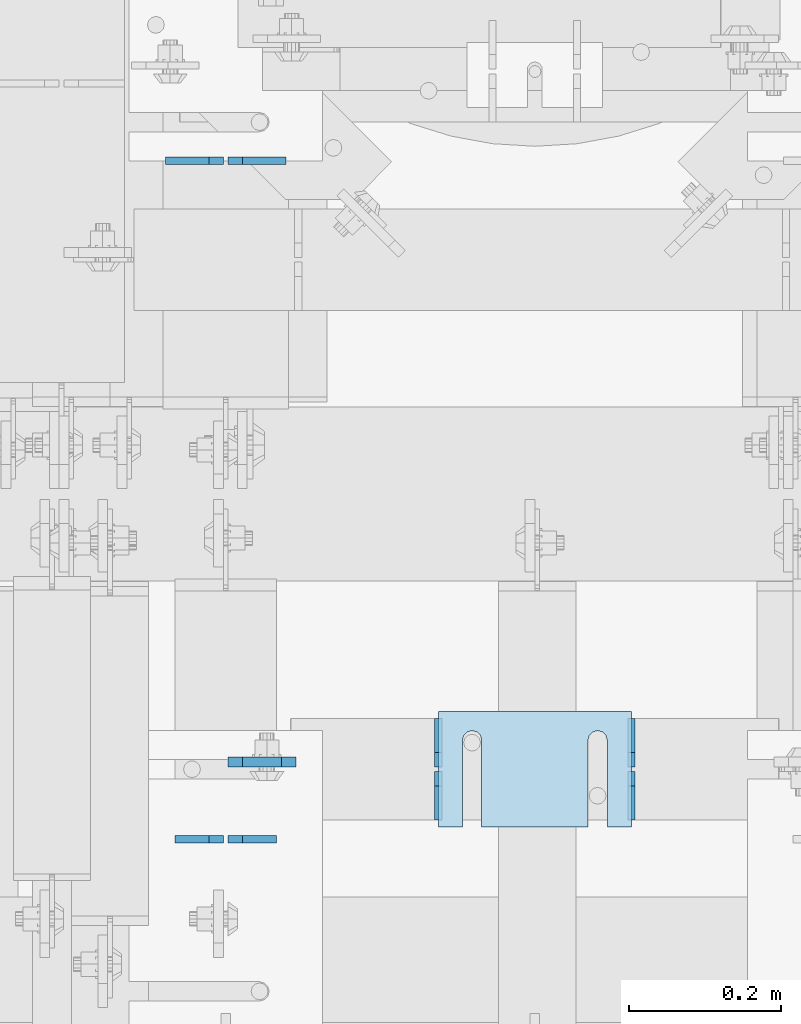
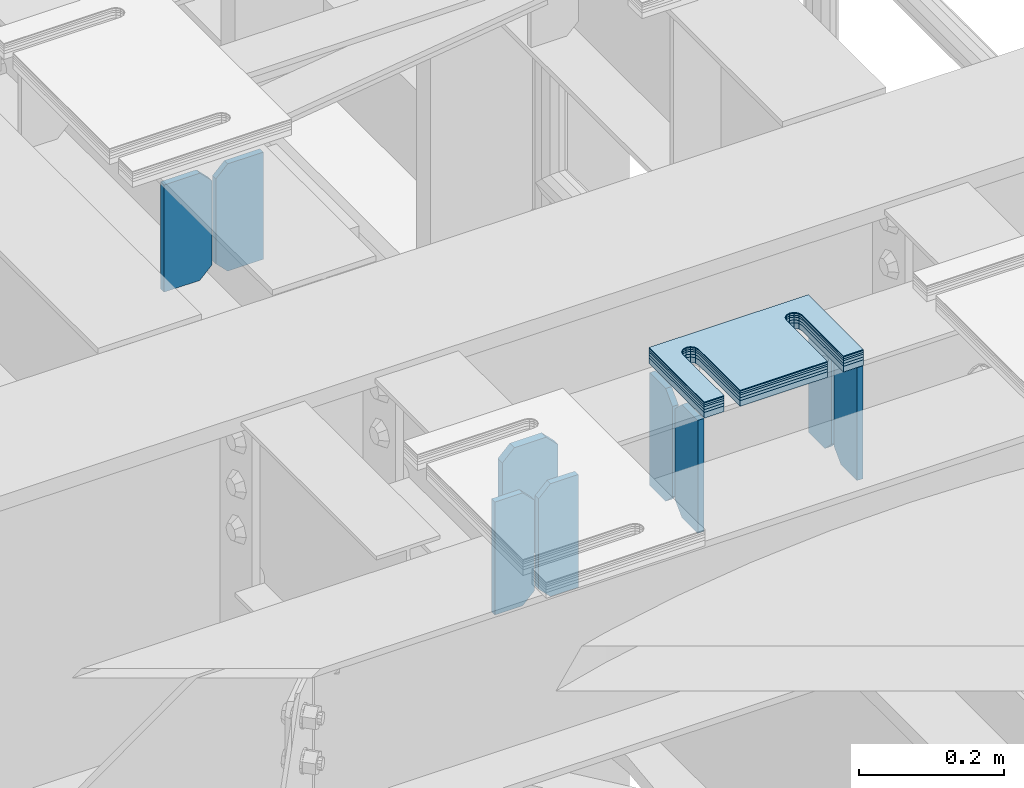
# One storey, part 1576 of 1876: 15 plates, 9 elements without a shape of their own.
"""IFC2X3 building model written with IfcOpenShell, lengths in millimetres."""

from ifc_helpers import new_model, si_unit, frame, origin_with_axes, place, context, subcontext, project, spatial, faceted_brep, material, type_object, element, aggregate, save


model = new_model("IFC2X3")

# Units and contexts
model_context = context("Model", 3, precision=1e-05, world=origin_with_axes())
body_context = subcontext(model_context, "Body", "Model", "MODEL_VIEW")
ifc_project = project(units=[si_unit("LENGTHUNIT", "METRE", prefix="MILLI"), si_unit("AREAUNIT", "SQUARE_METRE"), si_unit("VOLUMEUNIT", "CUBIC_METRE"), si_unit("MASSUNIT", "GRAM", prefix="KILO"), si_unit("TIMEUNIT", "SECOND"), si_unit("PLANEANGLEUNIT", "RADIAN"), si_unit("SOLIDANGLEUNIT", "STERADIAN"), si_unit("THERMODYNAMICTEMPERATUREUNIT", "DEGREE_CELSIUS"), si_unit("LUMINOUSINTENSITYUNIT", "LUMEN")], contexts=[model_context])

# Site, building, storey
site_placement = place(None, origin_with_axes())
site = spatial("IfcSite", under=ifc_project, at=site_placement, CompositionType="ELEMENT")
building_placement = place(site_placement, origin_with_axes())
building = spatial("IfcBuilding", under=site, at=building_placement, Name="Undefined", CompositionType="ELEMENT")
storey_placement = place(building_placement, origin_with_axes())
storey = spatial("IfcBuildingStorey", under=building, at=storey_placement, Name="Undefined", CompositionType="ELEMENT", Elevation=0.0)

# Assembly, plates
assembly_1_placement = place(storey_placement, origin_with_axes())
assembly_1 = element("IfcElementAssembly", 1, at=assembly_1_placement, inside=storey, Name="BEAM", AssemblyPlace="NOTDEFINED", PredefinedType="RIGID_FRAME")
ifc_material = material(Name="STEEL/A36")
plate_type_1 = type_object("IfcPlateType", PredefinedType="NOTDEFINED")
plate_1_placement = place(assembly_1_placement, frame((4092.57517785198, 1962.15312686004, 17792.7000000684), z_axis=(0.0, 0.0, 1.0), x_axis=(-1.0, 0.0, 0.0)))
plate_1 = element("IfcPlate", 2, at=plate_1_placement, type_object=plate_type_1, material=ifc_material, Name="PLATE", context=body_context, shape_type="Brep", body=[
    faceted_brep([(0.0, -4.76249999999982, 0.0), (0.0, -4.76249999999982, 180.975006103516), (0.0, 4.76249999999982, 180.975006103516), (0.0, 4.76249999999982, 0.0), (57.1499977111816, -4.76249999999982, 180.975006103516), (57.1499977111816, 4.76249999999982, 180.975006103516), (76.1999969482422, -4.76249999999982, 161.925006866455), (76.1999969482422, 4.76249999999982, 161.925006866455), (76.1999969482422, -4.76249999999982, 19.0499992370605), (76.1999969482422, 4.76249999999982, 19.0499992370605), (57.1499977111816, -4.76249999999982, 0.0), (57.1499977111816, 4.76249999999982, 0.0)], [[[0, 1, 2, 3]], [[1, 4, 5, 2]], [[4, 6, 7, 5]], [[6, 8, 9, 7]], [[8, 10, 11, 9]], [[10, 0, 3, 11]], [[5, 7, 9, 11, 3, 2]], [[10, 8, 6, 4, 1, 0]]]),
])
plate_2_placement = place(assembly_1_placement, frame((4010.02517785198, 1962.15312686004, 17792.7), z_axis=(0.0, 0.0, 1.0), x_axis=(-1.0, 0.0, 0.0)))
plate_2 = element("IfcPlate", 3, at=plate_2_placement, type_object=plate_type_1, material=ifc_material, Name="PLATE", context=body_context, shape_type="Brep", body=[
    faceted_brep([(0.0, -4.76249999999982, 19.0499992370605), (0.0, -4.76249999999982, 161.925006866455), (0.0, 4.76249999999982, 161.925006866455), (0.0, 4.76249999999982, 19.0499992370605), (19.0499992370605, -4.76249999999982, 180.975006103516), (19.0499992370605, 4.76249999999982, 180.975006103516), (76.1999969482422, -4.76249999999982, 180.975006103516), (76.1999969482422, 4.76249999999982, 180.975006103516), (76.1999969482422, -4.76250000000073, 0.0), (76.1999969482422, 4.76250000000073, 0.0), (19.0499992370605, -4.76249999999982, 0.0), (19.0499992370605, 4.76249999999982, 0.0)], [[[0, 1, 2, 3]], [[1, 4, 5, 2]], [[4, 6, 7, 5]], [[6, 8, 9, 7]], [[8, 10, 11, 9]], [[10, 0, 3, 11]], [[5, 7, 9, 11, 3, 2]], [[10, 8, 6, 4, 1, 0]]]),
])
aggregate(assembly_1, [plate_1, plate_2])

assembly_2_placement = place(storey_placement, origin_with_axes())
assembly_2 = element("IfcElementAssembly", 4, at=assembly_2_placement, inside=storey, Name="BEAM", AssemblyPlace="NOTDEFINED", PredefinedType="RIGID_FRAME")
plate_type_2 = type_object("IfcPlateType", PredefinedType="NOTDEFINED")
plate_3_placement = place(assembly_2_placement, frame((4546.61120385295, 1095.37530517578, 17784.7625), z_axis=(0.0, 0.0, 1.0), x_axis=(0.0, 1.0, 0.0)))
plate_3 = element("IfcPlate", 5, at=plate_3_placement, type_object=plate_type_2, material=ifc_material, Name="PLATE", context=body_context, shape_type="Brep", body=[
    faceted_brep([(0.0, -4.76249999999982, 0.0), (0.0, -4.76249999999982, 190.5), (0.0, 4.76249999999982, 190.5), (0.0, 4.76249999999982, 0.0), (44.4500007629395, -4.76249999999982, 190.5), (44.4500007629395, 4.76249999999982, 190.5), (63.5, -4.76249999999982, 171.450000762939), (63.5, 4.76249999999982, 171.450000762939), (63.5, -4.76249999999982, 19.0499992370605), (63.5, 4.76249999999982, 19.0499992370605), (44.4500007629395, -4.76249999999982, 0.0), (44.4500007629395, 4.76249999999982, 0.0)], [[[0, 1, 2, 3]], [[1, 4, 5, 2]], [[4, 6, 7, 5]], [[6, 8, 9, 7]], [[8, 10, 11, 9]], [[10, 0, 3, 11]], [[5, 7, 9, 11, 3, 2]], [[10, 8, 6, 4, 1, 0]]]),
])
plate_4_placement = place(assembly_2_placement, frame((4546.61120385295, 1165.22530517578, 17784.7625), z_axis=(0.0, 0.0, 1.0), x_axis=(0.0, 1.0, 0.0)))
plate_4 = element("IfcPlate", 6, at=plate_4_placement, type_object=plate_type_2, material=ifc_material, Name="PLATE", context=body_context, shape_type="Brep", body=[
    faceted_brep([(0.0, -4.76249999999982, 19.0499992370605), (0.0, -4.76249999999982, 171.450000762939), (0.0, 4.76249999999982, 171.450000762939), (0.0, 4.76249999999982, 19.0499992370605), (19.0499992370605, -4.76249999999982, 190.5), (19.0499992370605, 4.76249999999982, 190.5), (63.5, -4.76249999999982, 190.5), (63.5, 4.76249999999982, 190.5), (63.5, -4.76249999999982, 0.0), (63.5, 4.76249999999982, 0.0), (19.0499992370605, -4.76249999999982, 0.0), (19.0499992370605, 4.76249999999982, 0.0)], [[[0, 1, 2, 3]], [[1, 4, 5, 2]], [[4, 6, 7, 5]], [[6, 8, 9, 7]], [[8, 10, 11, 9]], [[10, 0, 3, 11]], [[5, 7, 9, 11, 3, 2]], [[10, 8, 6, 4, 1, 0]]]),
])
plate_5_placement = place(assembly_2_placement, frame((4292.61203778016, 1095.37530517578, 17784.7625), z_axis=(0.0, 0.0, 1.0), x_axis=(0.0, 1.0, 0.0)))
plate_5 = element("IfcPlate", 7, at=plate_5_placement, type_object=plate_type_2, material=ifc_material, Name="PLATE", context=body_context, shape_type="Brep", body=[
    faceted_brep([(0.0, -4.76249999999982, 0.0), (0.0, -4.76249999999982, 190.5), (0.0, 4.76249999999982, 190.5), (0.0, 4.76249999999982, 0.0), (44.4500007629395, -4.76249999999982, 190.5), (44.4500007629395, 4.76249999999982, 190.5), (63.5, -4.76249999999982, 171.450000762939), (63.5, 4.76249999999982, 171.450000762939), (63.5, -4.76249999999982, 19.0499992370605), (63.5, 4.76249999999982, 19.0499992370605), (44.4500007629395, -4.76249999999982, 0.0), (44.4500007629395, 4.76249999999982, 0.0)], [[[0, 1, 2, 3]], [[1, 4, 5, 2]], [[4, 6, 7, 5]], [[6, 8, 9, 7]], [[8, 10, 11, 9]], [[10, 0, 3, 11]], [[5, 7, 9, 11, 3, 2]], [[10, 8, 6, 4, 1, 0]]]),
])
plate_6_placement = place(assembly_2_placement, frame((4292.61203778016, 1165.22530517578, 17784.7625), z_axis=(0.0, 0.0, 1.0), x_axis=(0.0, 1.0, 0.0)))
plate_6 = element("IfcPlate", 8, at=plate_6_placement, type_object=plate_type_2, material=ifc_material, Name="PLATE", context=body_context, shape_type="Brep", body=[
    faceted_brep([(0.0, -4.76249999999982, 19.0499992370605), (0.0, -4.76249999999982, 171.450000762939), (0.0, 4.76249999999982, 171.450000762939), (0.0, 4.76249999999982, 19.0499992370605), (19.0499992370605, -4.76249999999982, 190.5), (19.0499992370605, 4.76249999999982, 190.5), (63.5, -4.76249999999982, 190.5), (63.5, 4.76249999999982, 190.5), (63.5, -4.76249999999982, 0.0), (63.5, 4.76249999999982, 0.0), (19.0499992370605, -4.76249999999982, 0.0), (19.0499992370605, 4.76249999999982, 0.0)], [[[0, 1, 2, 3]], [[1, 4, 5, 2]], [[4, 6, 7, 5]], [[6, 8, 9, 7]], [[8, 10, 11, 9]], [[10, 0, 3, 11]], [[5, 7, 9, 11, 3, 2]], [[10, 8, 6, 4, 1, 0]]]),
])
aggregate(assembly_2, [plate_3, plate_4, plate_5, plate_6])

assembly_3_placement = place(storey_placement, origin_with_axes())
assembly_3 = element("IfcElementAssembly", 9, at=assembly_3_placement, inside=storey, Name="BEAM", AssemblyPlace="NOTDEFINED", PredefinedType="RIGID_FRAME")
plate_7_placement = place(assembly_3_placement, frame((4079.87517785198, 1069.97506254369, 17784.7625), z_axis=(0.0, 0.0, 1.0), x_axis=(-1.0, 0.0, 0.0)))
plate_7 = element("IfcPlate", 10, at=plate_7_placement, type_object=plate_type_2, material=ifc_material, Name="PLATE", context=body_context, shape_type="Brep", body=[
    faceted_brep([(0.0, -4.76249999999982, 0.0), (0.0, -4.76249999999982, 190.5), (0.0, 4.76249999999982, 190.5), (0.0, 4.76249999999982, 0.0), (44.4500007629395, -4.76249999999982, 190.5), (44.4500007629395, 4.76249999999982, 190.5), (63.5, -4.76249999999982, 171.450000762939), (63.5, 4.76249999999982, 171.450000762939), (63.5, -4.76249999999982, 19.0499992370605), (63.5, 4.76249999999982, 19.0499992370605), (44.4500007629395, -4.76249999999982, 0.0), (44.4500007629395, 4.76249999999982, 0.0)], [[[0, 1, 2, 3]], [[1, 4, 5, 2]], [[4, 6, 7, 5]], [[6, 8, 9, 7]], [[8, 10, 11, 9]], [[10, 0, 3, 11]], [[5, 7, 9, 11, 3, 2]], [[10, 8, 6, 4, 1, 0]]]),
])
plate_8_placement = place(assembly_3_placement, frame((4010.02517785198, 1069.97506254369, 17784.7625), z_axis=(0.0, 0.0, 1.0), x_axis=(-1.0, 0.0, 0.0)))
plate_8 = element("IfcPlate", 11, at=plate_8_placement, type_object=plate_type_2, material=ifc_material, Name="PLATE", context=body_context, shape_type="Brep", body=[
    faceted_brep([(0.0, -4.76249999999982, 19.0499992370605), (0.0, -4.76249999999982, 171.450000762939), (0.0, 4.76249999999982, 171.450000762939), (0.0, 4.76249999999982, 19.0499992370605), (19.0499992370605, -4.76249999999982, 190.5), (19.0499992370605, 4.76249999999982, 190.5), (63.5, -4.76249999999982, 190.5), (63.5, 4.76249999999982, 190.5), (63.5, -4.76249999999982, 0.0), (63.5, 4.76249999999982, 0.0), (19.0499992370605, -4.76249999999982, 0.0), (19.0499992370605, 4.76249999999982, 0.0)], [[[0, 1, 2, 3]], [[1, 4, 5, 2]], [[4, 6, 7, 5]], [[6, 8, 9, 7]], [[8, 10, 11, 9]], [[10, 0, 3, 11]], [[5, 7, 9, 11, 3, 2]], [[10, 8, 6, 4, 1, 0]]]),
])
plate_type_3 = type_object("IfcPlateType", PredefinedType="NOTDEFINED")
plate_9_placement = place(assembly_3_placement, frame((4016.37517785198, 1171.57530527115, 17786.35), z_axis=(0.0, 0.0, 1.0), x_axis=(1.0, 0.0, 0.0)))
plate_9 = element("IfcPlate", 12, at=plate_9_placement, type_object=plate_type_3, material=ifc_material, Name="PLATE", context=body_context, shape_type="Brep", body=[
    faceted_brep([(0.0, -6.35000000000196, 19.0499992370605), (0.0, -6.34999999999991, 169.862506866455), (0.0, 6.34999999999991, 169.862506866455), (0.0, 6.35000000000105, 19.0499992370605), (19.0499992370605, -6.34999999999991, 188.912506103516), (19.0499992370605, 6.34999999999991, 188.912506103516), (69.8500022888184, -6.34999999999991, 188.912506103516), (69.8500022888184, 6.34999999999991, 188.912506103516), (88.9000015258789, -6.34999999999991, 169.862506866455), (88.9000015258789, 6.34999999999991, 169.862506866455), (88.9000015258789, -6.34999999999991, 0.0), (88.9000015258789, 6.34999999999991, 0.0), (19.0499992370642, -6.35000000000105, 0.0), (19.0499992370633, 6.35000000000105, 0.0)], [[[0, 1, 2, 3]], [[1, 4, 5, 2]], [[4, 6, 7, 5]], [[6, 8, 9, 7]], [[8, 10, 11, 9]], [[10, 12, 13, 11]], [[12, 0, 3, 13]], [[5, 7, 9, 11, 13, 3, 2]], [[12, 10, 8, 6, 4, 1, 0]]]),
])
aggregate(assembly_3, [plate_7, plate_8, plate_9])

# Assembly, plate
assembly_4_placement = place(storey_placement, origin_with_axes())
assembly_4 = element("IfcElementAssembly", 13, at=assembly_4_placement, inside=storey, Name="SHIM PLATE", AssemblyPlace="NOTDEFINED", PredefinedType="RIGID_FRAME")
plate_type_4 = type_object("IfcPlateType", PredefinedType="NOTDEFINED")
plate_10_placement = place(assembly_4_placement, frame((4546.61256679875, 1238.25105434561, 18009.3925), z_axis=(0.0, -1.0, 0.0), x_axis=(-1.0, 0.0, 0.0)))
plate_10 = element("IfcPlate", 14, at=plate_10_placement, type_object=plate_type_4, material=ifc_material, Name="SHIM PLATE", context=body_context, shape_type="Brep", body=[
    faceted_brep([(31.7473236467022, -0.793499999999767, 152.398895263674), (31.7495452849444, -0.793499999999767, 38.0994505459066), (31.7495452849444, 0.793499999999767, 38.0994505459066), (31.7473236467022, 0.793499999999767, 152.398895263674), (33.4510181364694, -0.793499999999767, 31.7494480392982), (33.4510181364694, 0.793499999999767, 31.7494480392982), (38.0995388011806, -0.793499999999767, 27.1009216783834), (38.0995388011806, 0.793499999999767, 27.1009216783834), (44.4495392228328, -0.793499999999767, 25.3994410457015), (44.4495392228328, 0.793499999999767, 25.3994410457015), (50.7995409628356, -0.793499999999767, 27.1009167582527), (50.7995409628356, 0.793499999999767, 27.1009167582527), (55.4480652293469, -0.793499999999767, 31.7494395173824), (55.4480652293469, 0.793499999999767, 31.7494395173824), (57.14954300102, -0.793499999999767, 38.0994407056476), (57.14954300102, 0.793499999999767, 38.0994407056476), (57.1473213626687, -0.793499999999767, 152.398894419415), (57.1473213626687, 0.793499999999767, 152.398895263676), (9.09494701772928e-13, -0.793499999999767, 0.0), (1.98268335225293e-05, -0.793499999999767, 152.398895263672), (1.98268335225293e-05, 0.793499999999767, 152.398895263672), (9.09494701772928e-13, 0.793499999999767, 0.0), (253.999542236328, -0.793499999999767, 6.16182660451159e-11), (253.999542236328, 0.793499999999767, 6.16182660451159e-11), (253.999557495107, -0.793499999999767, 152.398895263688), (253.999557495107, 0.793499999999767, 152.398895263688), (222.247321362667, 0.793499999999767, 152.398895263686), (222.247321362667, -0.793499999999767, 152.398895410166), (222.249543001019, 0.793499999999767, 38.0994416963979), (222.249543001019, -0.793499999999767, 38.0994416963979), (220.548065229345, 0.793499999999767, 31.7494405081325), (220.548065229345, -0.793499999999767, 31.7494405081325), (215.899540962834, 0.793499999999767, 27.100917749003), (215.899540962834, -0.793499999999767, 27.100917749003), (209.549539222831, 0.793499999999767, 25.3994420364518), (209.549539222831, -0.793499999999767, 25.3994420364518), (203.199538801179, 0.793499999999767, 27.1009226691335), (203.199538801179, -0.793499999999767, 27.1009226691335), (198.551018136468, 0.793499999999767, 31.7494490300483), (198.551018136468, -0.793499999999767, 31.7494490300483), (196.849545284943, 0.793499999999767, 38.0994515366567), (196.849545284943, -0.793499999999767, 38.0994515366567), (196.847323646701, -0.793499999999767, 152.398895263684), (196.847323646701, 0.793499999999767, 152.398895263684)], [[[0, 1, 2, 3]], [[4, 5, 2, 1]], [[6, 7, 5, 4]], [[8, 9, 7, 6]], [[10, 11, 9, 8]], [[12, 13, 11, 10]], [[14, 15, 13, 12]], [[16, 17, 15, 14]], [[18, 19, 20, 21]], [[22, 18, 21, 23]], [[24, 22, 23, 25]], [[24, 25, 26, 27]], [[27, 26, 28, 29]], [[29, 28, 30, 31]], [[31, 30, 32, 33]], [[33, 32, 34, 35]], [[35, 34, 36, 37]], [[37, 36, 38, 39]], [[39, 38, 40, 41]], [[42, 41, 40, 43]], [[12, 10, 8, 6, 4, 1, 0, 19, 18, 22, 24, 27, 29, 31, 33, 35, 37, 39, 41, 42, 16, 14]], [[20, 19, 0, 3]], [[43, 40, 38, 36, 34, 32, 30, 28, 26, 25, 23, 21, 20, 3, 2, 5, 7, 9, 11, 13, 15, 17]], [[42, 43, 17, 16]]]),
])
aggregate(assembly_4, [plate_10])

assembly_5_placement = place(storey_placement, origin_with_axes())
assembly_5 = element("IfcElementAssembly", 15, at=assembly_5_placement, inside=storey, Name="SHIM PLATE", AssemblyPlace="NOTDEFINED", PredefinedType="RIGID_FRAME")
plate_type_5 = type_object("IfcPlateType", PredefinedType="NOTDEFINED")
plate_11_placement = place(assembly_5_placement, frame((4546.61256679889, 1238.25105434514, 18007.0115), z_axis=(0.0, -1.0, 0.0), x_axis=(-1.0, 0.0, 0.0)))
plate_11 = element("IfcPlate", 16, at=plate_11_placement, type_object=plate_type_5, material=ifc_material, Name="SHIM PLATE", context=body_context, shape_type="Brep", body=[
    faceted_brep([(31.7473236467022, -1.58750000000146, 152.398895263674), (31.7495452849444, -1.58750000000146, 38.0994505459066), (31.7495452849444, 1.58750000000146, 38.0994505459066), (31.7473236467022, 1.58750000000146, 152.398895263674), (33.4510181364694, -1.58750000000146, 31.7494480392982), (33.4510181364694, 1.58750000000146, 31.7494480392982), (38.0995388011806, -1.58750000000146, 27.1009216783834), (38.0995388011806, 1.58750000000146, 27.1009216783834), (44.4495392228328, -1.58750000000146, 25.3994410457015), (44.4495392228328, 1.58750000000146, 25.3994410457015), (50.7995409628356, -1.58750000000146, 27.1009167582527), (50.7995409628356, 1.58750000000146, 27.1009167582527), (55.4480652293469, -1.58750000000146, 31.7494395173824), (55.4480652293469, 1.58750000000146, 31.7494395173824), (57.14954300102, -1.58750000000146, 38.0994407056476), (57.14954300102, 1.58750000000146, 38.0994407056476), (57.1473213626687, -1.58750000000146, 152.398894419415), (57.1473213626687, 1.58750000000146, 152.398895263676), (9.09494701772928e-13, -1.58750000000146, 4.54747350886464e-13), (1.98264133359771e-05, -1.58750000000146, 152.398895263672), (1.98264133359771e-05, 1.58750000000146, 152.398895263672), (9.09494701772928e-13, 1.58750000000146, 4.54747350886464e-13), (253.999542236328, -1.58750000000146, 6.16182660451159e-11), (253.999542236328, 1.58750000000146, 6.16182660451159e-11), (253.999557495107, -1.58750000000146, 152.398895263688), (253.999557495107, 1.58750000000146, 152.398895263688), (222.247321362667, 1.58750000000146, 152.398895263686), (222.247321362667, -1.58750000000146, 152.398895410166), (222.249543001019, 1.58750000000146, 38.0994416963979), (222.249543001019, -1.58750000000146, 38.0994416963979), (220.548065229345, 1.58750000000146, 31.7494405081325), (220.548065229345, -1.58750000000146, 31.7494405081325), (215.899540962834, 1.58750000000146, 27.100917749003), (215.899540962834, -1.58750000000146, 27.100917749003), (209.549539222831, 1.58750000000146, 25.3994420364518), (209.549539222831, -1.58750000000146, 25.3994420364518), (203.199538801179, 1.58750000000146, 27.1009226691335), (203.199538801179, -1.58750000000146, 27.1009226691335), (198.551018136468, 1.58750000000146, 31.7494490300483), (198.551018136468, -1.58750000000146, 31.7494490300483), (196.849545284943, 1.58750000000146, 38.0994515366567), (196.849545284943, -1.58750000000146, 38.0994515366567), (196.847323646701, -1.58750000000146, 152.398895263684), (196.847323646701, 1.58750000000146, 152.398895263684)], [[[0, 1, 2, 3]], [[4, 5, 2, 1]], [[6, 7, 5, 4]], [[8, 9, 7, 6]], [[10, 11, 9, 8]], [[12, 13, 11, 10]], [[14, 15, 13, 12]], [[16, 17, 15, 14]], [[18, 19, 20, 21]], [[22, 18, 21, 23]], [[24, 22, 23, 25]], [[24, 25, 26, 27]], [[27, 26, 28, 29]], [[29, 28, 30, 31]], [[31, 30, 32, 33]], [[33, 32, 34, 35]], [[35, 34, 36, 37]], [[37, 36, 38, 39]], [[39, 38, 40, 41]], [[42, 41, 40, 43]], [[12, 10, 8, 6, 4, 1, 0, 19, 18, 22, 24, 27, 29, 31, 33, 35, 37, 39, 41, 42, 16, 14]], [[20, 19, 0, 3]], [[43, 40, 38, 36, 34, 32, 30, 28, 26, 25, 23, 21, 20, 3, 2, 5, 7, 9, 11, 13, 15, 17]], [[42, 43, 17, 16]]]),
])
aggregate(assembly_5, [plate_11])

assembly_6_placement = place(storey_placement, origin_with_axes())
assembly_6 = element("IfcElementAssembly", 17, at=assembly_6_placement, inside=storey, Name="SHIM PLATE", AssemblyPlace="NOTDEFINED", PredefinedType="RIGID_FRAME")
plate_12_placement = place(assembly_6_placement, frame((4546.61256679903, 1238.25105434468, 18003.8365), z_axis=(0.0, -1.0, 0.0), x_axis=(-1.0, 0.0, 0.0)))
plate_12 = element("IfcPlate", 18, at=plate_12_placement, type_object=plate_type_5, material=ifc_material, Name="SHIM PLATE", context=body_context, shape_type="Brep", body=[
    faceted_brep([(31.7473236467022, -1.58750000000146, 152.398895263674), (31.7495452849444, -1.58750000000146, 38.0994505459066), (31.7495452849444, 1.58750000000146, 38.0994505459066), (31.7473236467022, 1.58750000000146, 152.398895263674), (33.4510181364694, -1.58750000000146, 31.7494480392982), (33.4510181364694, 1.58750000000146, 31.7494480392982), (38.0995388011806, -1.58750000000146, 27.1009216783834), (38.0995388011806, 1.58750000000146, 27.1009216783834), (44.4495392228328, -1.58750000000146, 25.3994410457015), (44.4495392228328, 1.58750000000146, 25.3994410457015), (50.7995409628356, -1.58750000000146, 27.1009167582527), (50.7995409628356, 1.58750000000146, 27.1009167582527), (55.4480652293469, -1.58750000000146, 31.7494395173824), (55.4480652293469, 1.58750000000146, 31.7494395173824), (57.14954300102, -1.58750000000146, 38.0994407056476), (57.14954300102, 1.58750000000146, 38.0994407056476), (57.1473213626687, -1.58750000000146, 152.398894419415), (57.1473213626687, 1.58750000000146, 152.398895263676), (9.09494701772928e-13, -1.58750000000146, 4.54747350886464e-13), (1.98264133359771e-05, -1.58750000000146, 152.398895263672), (1.98264133359771e-05, 1.58750000000146, 152.398895263672), (9.09494701772928e-13, 1.58750000000146, 4.54747350886464e-13), (253.999542236328, -1.58750000000146, 6.16182660451159e-11), (253.999542236328, 1.58750000000146, 6.16182660451159e-11), (253.999557495107, -1.58750000000146, 152.398895263688), (253.999557495107, 1.58750000000146, 152.398895263688), (222.247321362667, 1.58750000000146, 152.398895263686), (222.247321362667, -1.58750000000146, 152.398895410166), (222.249543001019, 1.58750000000146, 38.0994416963979), (222.249543001019, -1.58750000000146, 38.0994416963979), (220.548065229345, 1.58750000000146, 31.7494405081325), (220.548065229345, -1.58750000000146, 31.7494405081325), (215.899540962834, 1.58750000000146, 27.100917749003), (215.899540962834, -1.58750000000146, 27.100917749003), (209.549539222831, 1.58750000000146, 25.3994420364518), (209.549539222831, -1.58750000000146, 25.3994420364518), (203.199538801179, 1.58750000000146, 27.1009226691335), (203.199538801179, -1.58750000000146, 27.1009226691335), (198.551018136468, 1.58750000000146, 31.7494490300483), (198.551018136468, -1.58750000000146, 31.7494490300483), (196.849545284943, 1.58750000000146, 38.0994515366567), (196.849545284943, -1.58750000000146, 38.0994515366567), (196.847323646701, -1.58750000000146, 152.398895263684), (196.847323646701, 1.58750000000146, 152.398895263684)], [[[0, 1, 2, 3]], [[4, 5, 2, 1]], [[6, 7, 5, 4]], [[8, 9, 7, 6]], [[10, 11, 9, 8]], [[12, 13, 11, 10]], [[14, 15, 13, 12]], [[16, 17, 15, 14]], [[18, 19, 20, 21]], [[22, 18, 21, 23]], [[24, 22, 23, 25]], [[24, 25, 26, 27]], [[27, 26, 28, 29]], [[29, 28, 30, 31]], [[31, 30, 32, 33]], [[33, 32, 34, 35]], [[35, 34, 36, 37]], [[37, 36, 38, 39]], [[39, 38, 40, 41]], [[42, 41, 40, 43]], [[12, 10, 8, 6, 4, 1, 0, 19, 18, 22, 24, 27, 29, 31, 33, 35, 37, 39, 41, 42, 16, 14]], [[20, 19, 0, 3]], [[43, 40, 38, 36, 34, 32, 30, 28, 26, 25, 23, 21, 20, 3, 2, 5, 7, 9, 11, 13, 15, 17]], [[42, 43, 17, 16]]]),
])
aggregate(assembly_6, [plate_12])

assembly_7_placement = place(storey_placement, origin_with_axes())
assembly_7 = element("IfcElementAssembly", 19, at=assembly_7_placement, inside=storey, Name="SHIM PLATE", AssemblyPlace="NOTDEFINED", PredefinedType="RIGID_FRAME")
plate_type_6 = type_object("IfcPlateType", PredefinedType="NOTDEFINED")
plate_13_placement = place(assembly_7_placement, frame((4546.61256679916, 1238.25105434422, 17999.868), z_axis=(0.0, -1.0, 0.0), x_axis=(-1.0, 0.0, 0.0)))
plate_13 = element("IfcPlate", 20, at=plate_13_placement, type_object=plate_type_6, material=ifc_material, Name="SHIM PLATE", context=body_context, shape_type="Brep", body=[
    faceted_brep([(31.7473236467022, -2.38100000000122, 152.398895263674), (31.7495452849444, -2.38100000000122, 38.0994505459066), (31.7495452849444, 2.38100000000122, 38.0994505459066), (31.7473236467022, 2.38100000000122, 152.398895263674), (33.4510181364694, -2.38100000000122, 31.7494480392982), (33.4510181364694, 2.38100000000122, 31.7494480392982), (38.0995388011806, -2.38100000000122, 27.1009216783834), (38.0995388011806, 2.38100000000122, 27.1009216783834), (44.4495392228328, -2.38100000000122, 25.3994410457015), (44.4495392228328, 2.38100000000122, 25.3994410457015), (50.7995409628356, -2.38100000000122, 27.1009167582527), (50.7995409628356, 2.38100000000122, 27.1009167582527), (55.4480652293469, -2.38100000000122, 31.7494395173824), (55.4480652293469, 2.38100000000122, 31.7494395173824), (57.14954300102, -2.38100000000122, 38.0994407056476), (57.14954300102, 2.38100000000122, 38.0994407056476), (57.1473213626687, -2.38100000000122, 152.398894419415), (57.1473213626687, 2.38100000000122, 152.398895263676), (0.0, -2.38100000000122, 4.54747350886464e-13), (1.98259931494249e-05, -2.38100000000122, 152.398895263672), (1.98259931494249e-05, 2.38100000000122, 152.398895263672), (0.0, 2.38100000000122, 4.54747350886464e-13), (253.999542236328, -2.38100000000122, 6.16182660451159e-11), (253.999542236328, 2.38100000000122, 6.16182660451159e-11), (253.999557495107, -2.38100000000122, 152.398895263688), (253.999557495107, 2.38100000000122, 152.398895263688), (222.247321362667, 2.38100000000122, 152.398895263686), (222.247321362667, -2.38100000000122, 152.398895410166), (222.249543001019, 2.38100000000122, 38.0994416963979), (222.249543001019, -2.38100000000122, 38.0994416963979), (220.548065229345, 2.38100000000122, 31.7494405081325), (220.548065229345, -2.38100000000122, 31.7494405081325), (215.899540962834, 2.38100000000122, 27.100917749003), (215.899540962834, -2.38100000000122, 27.100917749003), (209.549539222831, 2.38100000000122, 25.3994420364518), (209.549539222831, -2.38100000000122, 25.3994420364518), (203.199538801179, 2.38100000000122, 27.1009226691335), (203.199538801179, -2.38100000000122, 27.1009226691335), (198.551018136468, 2.38100000000122, 31.7494490300483), (198.551018136468, -2.38100000000122, 31.7494490300483), (196.849545284943, 2.38100000000122, 38.0994515366567), (196.849545284943, -2.38100000000122, 38.0994515366567), (196.847323646701, -2.38100000000122, 152.398895263684), (196.847323646701, 2.38100000000122, 152.398895263684)], [[[0, 1, 2, 3]], [[4, 5, 2, 1]], [[6, 7, 5, 4]], [[8, 9, 7, 6]], [[10, 11, 9, 8]], [[12, 13, 11, 10]], [[14, 15, 13, 12]], [[16, 17, 15, 14]], [[18, 19, 20, 21]], [[22, 18, 21, 23]], [[24, 22, 23, 25]], [[24, 25, 26, 27]], [[27, 26, 28, 29]], [[29, 28, 30, 31]], [[31, 30, 32, 33]], [[33, 32, 34, 35]], [[35, 34, 36, 37]], [[37, 36, 38, 39]], [[39, 38, 40, 41]], [[42, 41, 40, 43]], [[12, 10, 8, 6, 4, 1, 0, 19, 18, 22, 24, 27, 29, 31, 33, 35, 37, 39, 41, 42, 16, 14]], [[20, 19, 0, 3]], [[43, 40, 38, 36, 34, 32, 30, 28, 26, 25, 23, 21, 20, 3, 2, 5, 7, 9, 11, 13, 15, 17]], [[42, 43, 17, 16]]]),
])
aggregate(assembly_7, [plate_13])

assembly_8_placement = place(storey_placement, origin_with_axes())
assembly_8 = element("IfcElementAssembly", 21, at=assembly_8_placement, inside=storey, Name="SHIM PLATE", AssemblyPlace="NOTDEFINED", PredefinedType="RIGID_FRAME")
plate_14_placement = place(assembly_8_placement, frame((4546.6125667993, 1238.25105434376, 17995.106), z_axis=(0.0, -1.0, 0.0), x_axis=(-1.0, 0.0, 0.0)))
plate_14 = element("IfcPlate", 22, at=plate_14_placement, type_object=plate_type_6, material=ifc_material, Name="SHIM PLATE", context=body_context, shape_type="Brep", body=[
    faceted_brep([(31.7473236467022, -2.38100000000122, 152.398895263674), (31.7495452849444, -2.38100000000122, 38.0994505459066), (31.7495452849444, 2.38100000000122, 38.0994505459066), (31.7473236467022, 2.38100000000122, 152.398895263674), (33.4510181364694, -2.38100000000122, 31.7494480392982), (33.4510181364694, 2.38100000000122, 31.7494480392982), (38.0995388011806, -2.38100000000122, 27.1009216783834), (38.0995388011806, 2.38100000000122, 27.1009216783834), (44.4495392228328, -2.38100000000122, 25.3994410457015), (44.4495392228328, 2.38100000000122, 25.3994410457015), (50.7995409628356, -2.38100000000122, 27.1009167582527), (50.7995409628356, 2.38100000000122, 27.1009167582527), (55.4480652293469, -2.38100000000122, 31.7494395173824), (55.4480652293469, 2.38100000000122, 31.7494395173824), (57.14954300102, -2.38100000000122, 38.0994407056476), (57.14954300102, 2.38100000000122, 38.0994407056476), (57.1473213626687, -2.38100000000122, 152.398894419415), (57.1473213626687, 2.38100000000122, 152.398895263676), (0.0, -2.38100000000122, 4.54747350886464e-13), (1.98259931494249e-05, -2.38100000000122, 152.398895263672), (1.98259931494249e-05, 2.38100000000122, 152.398895263672), (0.0, 2.38100000000122, 4.54747350886464e-13), (253.999542236328, -2.38100000000122, 6.16182660451159e-11), (253.999542236328, 2.38100000000122, 6.16182660451159e-11), (253.999557495107, -2.38100000000122, 152.398895263688), (253.999557495107, 2.38100000000122, 152.398895263688), (222.247321362667, 2.38100000000122, 152.398895263686), (222.247321362667, -2.38100000000122, 152.398895410166), (222.249543001019, 2.38100000000122, 38.0994416963979), (222.249543001019, -2.38100000000122, 38.0994416963979), (220.548065229345, 2.38100000000122, 31.7494405081325), (220.548065229345, -2.38100000000122, 31.7494405081325), (215.899540962834, 2.38100000000122, 27.100917749003), (215.899540962834, -2.38100000000122, 27.100917749003), (209.549539222831, 2.38100000000122, 25.3994420364518), (209.549539222831, -2.38100000000122, 25.3994420364518), (203.199538801179, 2.38100000000122, 27.1009226691335), (203.199538801179, -2.38100000000122, 27.1009226691335), (198.551018136468, 2.38100000000122, 31.7494490300483), (198.551018136468, -2.38100000000122, 31.7494490300483), (196.849545284943, 2.38100000000122, 38.0994515366567), (196.849545284943, -2.38100000000122, 38.0994515366567), (196.847323646701, -2.38100000000122, 152.398895263684), (196.847323646701, 2.38100000000122, 152.398895263684)], [[[0, 1, 2, 3]], [[4, 5, 2, 1]], [[6, 7, 5, 4]], [[8, 9, 7, 6]], [[10, 11, 9, 8]], [[12, 13, 11, 10]], [[14, 15, 13, 12]], [[16, 17, 15, 14]], [[18, 19, 20, 21]], [[22, 18, 21, 23]], [[24, 22, 23, 25]], [[24, 25, 26, 27]], [[27, 26, 28, 29]], [[29, 28, 30, 31]], [[31, 30, 32, 33]], [[33, 32, 34, 35]], [[35, 34, 36, 37]], [[37, 36, 38, 39]], [[39, 38, 40, 41]], [[42, 41, 40, 43]], [[12, 10, 8, 6, 4, 1, 0, 19, 18, 22, 24, 27, 29, 31, 33, 35, 37, 39, 41, 42, 16, 14]], [[20, 19, 0, 3]], [[43, 40, 38, 36, 34, 32, 30, 28, 26, 25, 23, 21, 20, 3, 2, 5, 7, 9, 11, 13, 15, 17]], [[42, 43, 17, 16]]]),
])
aggregate(assembly_8, [plate_14])

assembly_9_placement = place(storey_placement, origin_with_axes())
assembly_9 = element("IfcElementAssembly", 23, at=assembly_9_placement, inside=storey, Name="SHIM PLATE", AssemblyPlace="NOTDEFINED", PredefinedType="RIGID_FRAME")
plate_type_7 = type_object("IfcPlateType", PredefinedType="NOTDEFINED")
plate_15_placement = place(assembly_9_placement, frame((4546.61256679944, 1238.2510543433, 17987.9625), z_axis=(0.0, -1.0, 0.0), x_axis=(-1.0, 0.0, 0.0)))
plate_15 = element("IfcPlate", 24, at=plate_15_placement, type_object=plate_type_7, material=ifc_material, Name="SHIM PLATE", context=body_context, shape_type="Brep", body=[
    faceted_brep([(31.7473236467022, -4.76250000000073, 152.398895263674), (31.7495452849444, -4.76250000000073, 38.0994505459066), (31.7495452849444, 4.76250000000073, 38.0994505459066), (31.7473236467022, 4.76250000000073, 152.398895263674), (33.4510181364694, -4.76250000000073, 31.7494480392982), (33.4510181364694, 4.76250000000073, 31.7494480392982), (38.0995388011806, -4.76250000000073, 27.1009216783834), (38.0995388011806, 4.76250000000073, 27.1009216783834), (44.4495392228328, -4.76250000000073, 25.3994410457015), (44.4495392228328, 4.76250000000073, 25.3994410457015), (50.7995409628356, -4.76250000000073, 27.1009167582527), (50.7995409628356, 4.76250000000073, 27.1009167582527), (55.4480652293469, -4.76250000000073, 31.7494395173824), (55.4480652293469, 4.76250000000073, 31.7494395173824), (57.14954300102, -4.76250000000073, 38.0994407056476), (57.14954300102, 4.76250000000073, 38.0994407056476), (57.1473213626687, -4.76250000000073, 152.398894419415), (57.1473213626687, 4.76250000000073, 152.398895263676), (0.0, -4.76249999999982, 0.0), (1.98255729628727e-05, -4.76250000000073, 152.398895263672), (1.98255729628727e-05, 4.76250000000073, 152.398895263672), (0.0, 4.76249999999982, 0.0), (253.999542236328, -4.76250000000073, 6.16182660451159e-11), (253.999542236328, 4.76250000000073, 6.16182660451159e-11), (253.999557495107, -4.76250000000073, 152.398895263688), (253.999557495107, 4.76250000000073, 152.398895263688), (222.247321362667, 4.76250000000073, 152.398895263686), (222.247321362667, -4.76250000000073, 152.398895410166), (222.249543001019, 4.76250000000073, 38.0994416963979), (222.249543001019, -4.76250000000073, 38.0994416963979), (220.548065229345, 4.76250000000073, 31.7494405081325), (220.548065229345, -4.76250000000073, 31.7494405081325), (215.899540962834, 4.76250000000073, 27.100917749003), (215.899540962834, -4.76250000000073, 27.100917749003), (209.549539222831, 4.76250000000073, 25.3994420364518), (209.549539222831, -4.76250000000073, 25.3994420364518), (203.199538801179, 4.76250000000073, 27.1009226691335), (203.199538801179, -4.76250000000073, 27.1009226691335), (198.551018136468, 4.76250000000073, 31.7494490300483), (198.551018136468, -4.76250000000073, 31.7494490300483), (196.849545284943, 4.76250000000073, 38.0994515366567), (196.849545284943, -4.76250000000073, 38.0994515366567), (196.847323646701, -4.76250000000073, 152.398895263684), (196.847323646701, 4.76250000000073, 152.398895263684)], [[[0, 1, 2, 3]], [[4, 5, 2, 1]], [[6, 7, 5, 4]], [[8, 9, 7, 6]], [[10, 11, 9, 8]], [[12, 13, 11, 10]], [[14, 15, 13, 12]], [[16, 17, 15, 14]], [[18, 19, 20, 21]], [[22, 18, 21, 23]], [[24, 22, 23, 25]], [[24, 25, 26, 27]], [[27, 26, 28, 29]], [[29, 28, 30, 31]], [[31, 30, 32, 33]], [[33, 32, 34, 35]], [[35, 34, 36, 37]], [[37, 36, 38, 39]], [[39, 38, 40, 41]], [[42, 41, 40, 43]], [[12, 10, 8, 6, 4, 1, 0, 19, 18, 22, 24, 27, 29, 31, 33, 35, 37, 39, 41, 42, 16, 14]], [[20, 19, 0, 3]], [[43, 40, 38, 36, 34, 32, 30, 28, 26, 25, 23, 21, 20, 3, 2, 5, 7, 9, 11, 13, 15, 17]], [[42, 43, 17, 16]]]),
])
aggregate(assembly_9, [plate_15])

save(model, "model.ifc")
